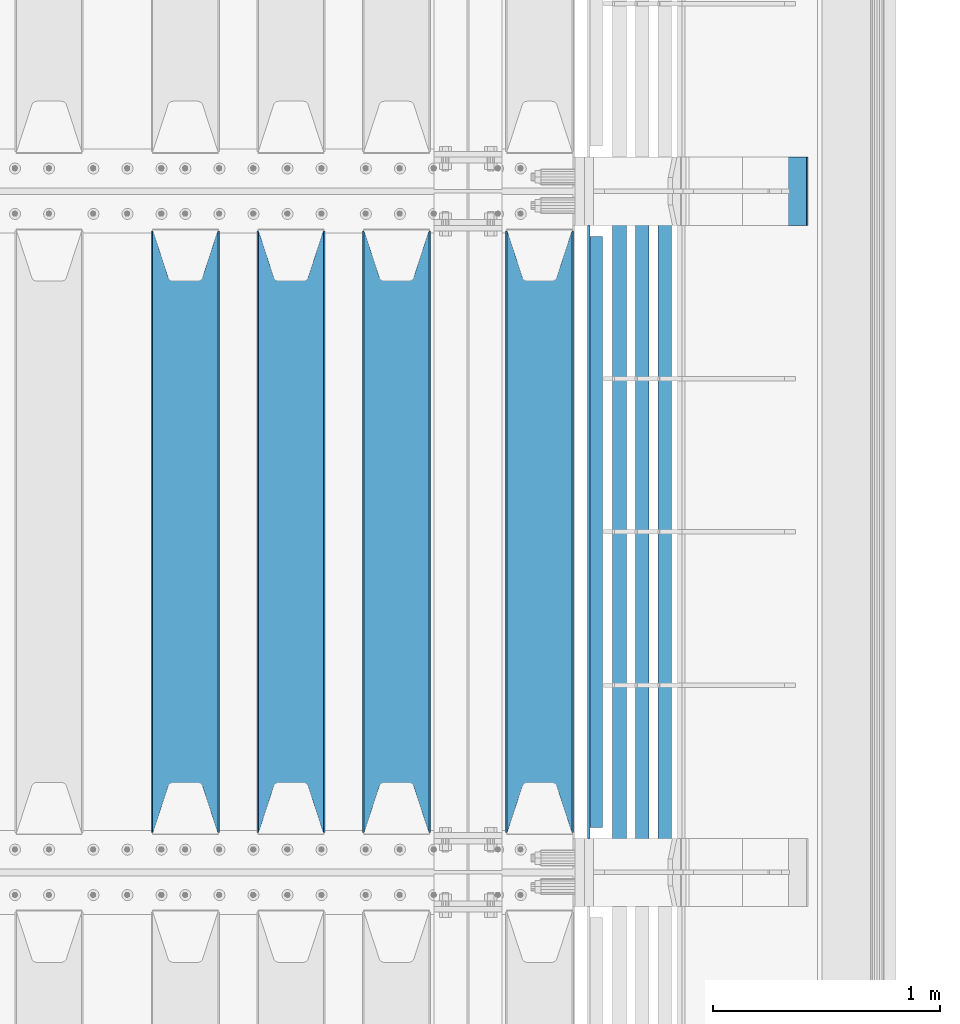
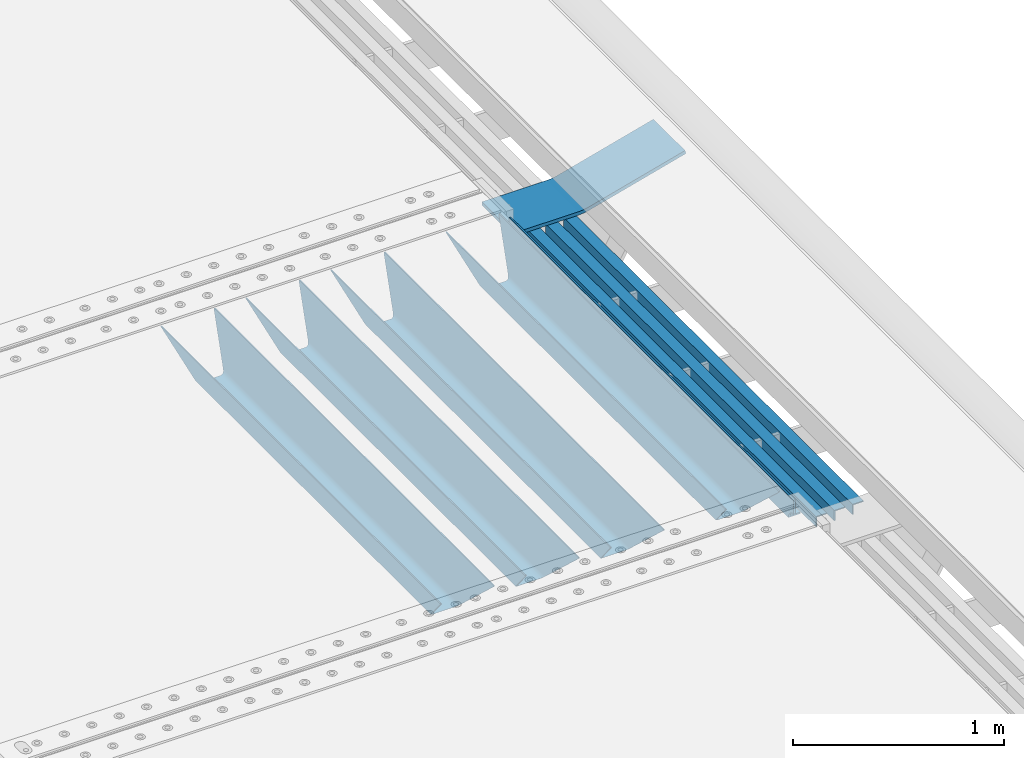
# One storey, part 131 of 257: 9 beams.
"""IFC2X3 building model written with IfcOpenShell, lengths in millimetres."""

from ifc_helpers import new_model, si_unit, frame, origin_with_axes, place, context, subcontext, project, spatial, faceted_brep, material, type_object, element, save


model = new_model("IFC2X3")

# Units and contexts
model_context = context("Model", 3, precision=1e-05, world=origin_with_axes())
body_context = subcontext(model_context, "Body", "Model", "MODEL_VIEW")
ifc_project = project(units=[si_unit("LENGTHUNIT", "METRE", prefix="MILLI"), si_unit("AREAUNIT", "SQUARE_METRE"), si_unit("VOLUMEUNIT", "CUBIC_METRE"), si_unit("MASSUNIT", "GRAM", prefix="KILO"), si_unit("TIMEUNIT", "SECOND"), si_unit("PLANEANGLEUNIT", "RADIAN"), si_unit("SOLIDANGLEUNIT", "STERADIAN"), si_unit("THERMODYNAMICTEMPERATUREUNIT", "DEGREE_CELSIUS"), si_unit("LUMINOUSINTENSITYUNIT", "LUMEN")], contexts=[model_context])

# Site, building, storey
site_placement = place(None, origin_with_axes())
site = spatial("IfcSite", under=ifc_project, at=site_placement, CompositionType="ELEMENT")
building_placement = place(site_placement, origin_with_axes())
building = spatial("IfcBuilding", under=site, at=building_placement, Name="Standard", CompositionType="ELEMENT")
storey_placement = place(building_placement, origin_with_axes())
storey = spatial("IfcBuildingStorey", under=building, at=storey_placement, Name="Undefined", CompositionType="ELEMENT", Elevation=0.0)

# Beams
ifc_material_1 = material(Name="STEEL/S355N")
beam_type_1 = type_object("IfcBeamType", PredefinedType="NOTDEFINED")
beam_1_placement = place(storey_placement, frame((59110.0, 3175.0, -115.0), z_axis=(0.0, 0.0, 1.0), x_axis=(0.0, 1.0, 0.0)))
element("IfcBeam", 1, at=beam_1_placement, inside=storey, type_object=beam_type_1, material=ifc_material_1, context=body_context, shape_type="Brep", body=[
    faceted_brep([(0.0, 150.0, 115.0), (0.0, 143.690000000002, 115.0), (2650.00000000297, 143.690000000002, 115.0), (2650.00000000297, 150.0, 115.0), (2650.00000000297, 142.059565218406, 110.0000000031), (2650.00000000297, 148.369565218403, 110.0000000031), (2441.90079219208, -80.1103600731149, -98.0992078077845), (2437.7588105432, -77.5672621345584, -102.241189456673), (2434.06523489746, -74.4080125315522, -105.934765102404), (2430.91086095089, -70.7102721255724, -109.089139048974), (2428.37322971128, -66.5649389910031, -111.626770288588), (2426.51472138055, -62.0739139532889, -113.485278619323), (2425.38102192091, -57.3475956567636, -114.618978078955), (2424.99999999987, -52.5021667386536, -115.0), (2424.99999999987, 52.5021667386536, -115.0), (2425.38102192091, 57.3475956567636, -114.618978078955), (2426.51472138055, 62.0739139532889, -113.485278619323), (2428.37322971128, 66.5649389910031, -111.626770288588), (2430.91086095089, 70.7102721255724, -109.089139048974), (2434.06523489746, 74.4080125315522, -105.934765102404), (2437.7588105432, 77.5672621345584, -102.241189456673), (2441.90079219208, 80.1103600731149, -98.0992078077846), (2446.38936140511, 81.9747917625791, -93.6106385947584), (2448.24948500409, 76.2713538057287, -91.7505149957729), (2444.62967112262, 74.76777986261, -95.3703288772456), (2441.28936334126, 72.7168944282894, -98.710636658607), (2438.31067330438, 70.1691124903809, -101.689326695487), (2435.76682334747, 67.1870637758839, -104.233176652398), (2433.72034654133, 63.8440531834931, -106.279653458539), (2432.22154950041, 60.2222587982324, -107.778450499454), (2431.30727574265, 56.4107117849126, -108.692724257221), (2430.99999999987, 52.5031078186876, -109.0), (2430.99999999987, -52.5031078186876, -109.0), (2431.30727574265, -56.4107117849126, -108.692724257221), (2432.22154950041, -60.2222587982324, -107.778450499454), (2433.72034654133, -63.8440531834931, -106.279653458539), (2435.76682334747, -67.1870637758839, -104.233176652398), (2438.31067330438, -70.1691124903809, -101.689326695487), (2441.28936334126, -72.7168944282894, -98.7106366586071), (2444.62967112262, -74.76777986261, -95.3703288772457), (2448.24948500409, -76.2713538057287, -91.7505149957729), (2650.00000000297, -142.059565218406, 110.0000000031), (2650.00000000297, -148.369565218403, 110.0000000031), (2446.38936140511, -81.9747917625791, -93.6106385947584), (2650.00000000297, -143.690000000002, 115.0), (2650.00000000297, -150.0, 115.0), (0.0, -143.690000000002, 115.0), (0.0, -150.0, 115.0), (0.0, -148.369565218258, 110.000000002662), (203.61063859742, -81.9747917625791, -93.6106385947584), (208.099207810447, -80.1103600731149, -98.0992078077845), (212.241189459335, -77.5672621345584, -102.241189456673), (215.934765105066, -74.4080125315522, -105.934765102404), (219.089139051636, -70.7102721255724, -109.089139048974), (221.626770291251, -66.5649389910031, -111.626770288588), (223.485278621985, -62.0739139532889, -113.485278619323), (224.618978081617, -57.3475956567636, -114.618978078955), (225.000000002662, -52.5021667386536, -115.0), (225.000000002662, 52.5021667386536, -115.0), (224.618978081617, 57.3475956567636, -114.618978078955), (223.485278621985, 62.0739139532889, -113.485278619323), (221.626770291251, 66.5649389910031, -111.626770288588), (219.089139051636, 70.7102721255724, -109.089139048974), (215.934765105066, 74.4080125315522, -105.934765102404), (212.241189459335, 77.5672621345584, -102.241189456673), (208.099207810447, 80.1103600731149, -98.0992078077846), (203.61063859742, 81.9747917625791, -93.6106385947584), (0.0, 148.369565218258, 110.000000002662), (0.0, 142.05956521826, 110.000000002662), (201.750514998435, 76.2713538057287, -91.7505149957729), (205.370328879908, 74.76777986261, -95.3703288772456), (208.710636661269, 72.7168944282894, -98.710636658607), (211.689326698149, 70.1691124903809, -101.689326695487), (214.233176655061, 67.1870637758839, -104.233176652398), (216.279653461201, 63.8440531834931, -106.279653458539), (217.778450502116, 60.2222587982324, -107.778450499454), (218.692724259884, 56.4107117849126, -108.692724257221), (219.000000002662, 52.5031078186876, -109.0), (219.000000002662, -52.5031078186876, -109.0), (218.692724259884, -56.4107117849126, -108.692724257221), (217.778450502116, -60.2222587982324, -107.778450499454), (216.279653461201, -63.8440531834931, -106.279653458539), (214.233176655061, -67.1870637758839, -104.233176652398), (211.689326698149, -70.1691124903809, -101.689326695487), (208.710636661269, -72.7168944282894, -98.7106366586071), (205.370328879908, -74.76777986261, -95.3703288772457), (201.750514998435, -76.2713538057287, -91.7505149957729), (0.0, -142.05956521826, 110.000000002662)], [[[0, 1, 2, 3]], [[3, 2, 4, 5]], [[6, 7, 8, 9, 10, 11, 12, 13, 14, 15, 16, 17, 18, 19, 20, 21, 22, 5, 4, 23, 24, 25, 26, 27, 28, 29, 30, 31, 32, 33, 34, 35, 36, 37, 38, 39, 40, 41, 42, 43]], [[44, 45, 42, 41]], [[46, 47, 45, 44]], [[43, 42, 45, 47, 48, 49]], [[6, 43, 49, 50]], [[7, 6, 50, 51]], [[8, 7, 51, 52]], [[9, 8, 52, 53]], [[10, 9, 53, 54]], [[11, 10, 54, 55]], [[12, 11, 55, 56]], [[13, 12, 56, 57]], [[14, 13, 57, 58]], [[15, 14, 58, 59]], [[16, 15, 59, 60]], [[17, 16, 60, 61]], [[18, 17, 61, 62]], [[19, 18, 62, 63]], [[20, 19, 63, 64]], [[21, 20, 64, 65]], [[22, 21, 65, 66]], [[0, 3, 5, 22, 66, 67]], [[1, 0, 67, 68]], [[23, 4, 2, 1, 68, 69]], [[24, 23, 69, 70]], [[25, 24, 70, 71]], [[26, 25, 71, 72]], [[27, 26, 72, 73]], [[28, 27, 73, 74]], [[29, 28, 74, 75]], [[30, 29, 75, 76]], [[31, 30, 76, 77]], [[32, 31, 77, 78]], [[33, 32, 78, 79]], [[34, 33, 79, 80]], [[35, 34, 80, 81]], [[36, 35, 81, 82]], [[37, 36, 82, 83]], [[38, 37, 83, 84]], [[39, 38, 84, 85]], [[40, 39, 85, 86]], [[46, 44, 41, 40, 86, 87]], [[47, 46, 87, 48]], [[86, 85, 84, 83, 82, 81, 80, 79, 78, 77, 76, 75, 74, 73, 72, 71, 70, 69, 68, 67, 66, 65, 64, 63, 62, 61, 60, 59, 58, 57, 56, 55, 54, 53, 52, 51, 50, 49, 48, 87]]]),
])
beam_2_placement = place(storey_placement, frame((58480.0, 3175.0, -115.0), z_axis=(0.0, 0.0, 1.0), x_axis=(0.0, 1.0, 0.0)))
element("IfcBeam", 2, at=beam_2_placement, inside=storey, type_object=beam_type_1, material=ifc_material_1, context=body_context, shape_type="Brep", body=[
    faceted_brep([(0.0, 150.0, 115.0), (0.0, 143.690000000002, 115.0), (2650.00000000297, 143.690000000002, 115.0), (2650.00000000297, 150.0, 115.0), (2650.00000000297, 142.059565218406, 110.0000000031), (2650.00000000297, 148.369565218403, 110.0000000031), (2441.90079219208, -80.1103600731149, -98.0992078077845), (2437.7588105432, -77.5672621345584, -102.241189456673), (2434.06523489746, -74.4080125315522, -105.934765102404), (2430.91086095089, -70.7102721255724, -109.089139048974), (2428.37322971128, -66.5649389910031, -111.626770288588), (2426.51472138055, -62.0739139532889, -113.485278619323), (2425.38102192091, -57.3475956567636, -114.618978078955), (2424.99999999987, -52.5021667386536, -115.0), (2424.99999999987, 52.5021667386536, -115.0), (2425.38102192091, 57.3475956567636, -114.618978078955), (2426.51472138055, 62.0739139532889, -113.485278619323), (2428.37322971128, 66.5649389910031, -111.626770288588), (2430.91086095089, 70.7102721255724, -109.089139048974), (2434.06523489746, 74.4080125315522, -105.934765102404), (2437.7588105432, 77.5672621345584, -102.241189456673), (2441.90079219208, 80.1103600731149, -98.0992078077846), (2446.38936140511, 81.9747917625791, -93.6106385947584), (2448.24948500409, 76.2713538057287, -91.7505149957729), (2444.62967112262, 74.76777986261, -95.3703288772456), (2441.28936334126, 72.7168944282894, -98.710636658607), (2438.31067330438, 70.1691124903809, -101.689326695487), (2435.76682334747, 67.1870637758839, -104.233176652398), (2433.72034654133, 63.8440531834931, -106.279653458539), (2432.22154950041, 60.2222587982324, -107.778450499454), (2431.30727574265, 56.4107117849126, -108.692724257221), (2430.99999999987, 52.5031078186876, -109.0), (2430.99999999987, -52.5031078186876, -109.0), (2431.30727574265, -56.4107117849126, -108.692724257221), (2432.22154950041, -60.2222587982324, -107.778450499454), (2433.72034654133, -63.8440531834931, -106.279653458539), (2435.76682334747, -67.1870637758839, -104.233176652398), (2438.31067330438, -70.1691124903809, -101.689326695487), (2441.28936334126, -72.7168944282894, -98.7106366586071), (2444.62967112262, -74.76777986261, -95.3703288772457), (2448.24948500409, -76.2713538057287, -91.7505149957729), (2650.00000000297, -142.059565218406, 110.0000000031), (2650.00000000297, -148.369565218403, 110.0000000031), (2446.38936140511, -81.9747917625791, -93.6106385947584), (2650.00000000297, -143.690000000002, 115.0), (2650.00000000297, -150.0, 115.0), (0.0, -143.690000000002, 115.0), (0.0, -150.0, 115.0), (0.0, -148.369565218258, 110.000000002662), (203.61063859742, -81.9747917625791, -93.6106385947584), (208.099207810447, -80.1103600731149, -98.0992078077845), (212.241189459335, -77.5672621345584, -102.241189456673), (215.934765105066, -74.4080125315522, -105.934765102404), (219.089139051636, -70.7102721255724, -109.089139048974), (221.626770291251, -66.5649389910031, -111.626770288588), (223.485278621985, -62.0739139532889, -113.485278619323), (224.618978081617, -57.3475956567636, -114.618978078955), (225.000000002662, -52.5021667386536, -115.0), (225.000000002662, 52.5021667386536, -115.0), (224.618978081617, 57.3475956567636, -114.618978078955), (223.485278621985, 62.0739139532889, -113.485278619323), (221.626770291251, 66.5649389910031, -111.626770288588), (219.089139051636, 70.7102721255724, -109.089139048974), (215.934765105066, 74.4080125315522, -105.934765102404), (212.241189459335, 77.5672621345584, -102.241189456673), (208.099207810447, 80.1103600731149, -98.0992078077846), (203.61063859742, 81.9747917625791, -93.6106385947584), (0.0, 148.369565218258, 110.000000002662), (0.0, 142.05956521826, 110.000000002662), (201.750514998435, 76.2713538057287, -91.7505149957729), (205.370328879908, 74.76777986261, -95.3703288772456), (208.710636661269, 72.7168944282894, -98.710636658607), (211.689326698149, 70.1691124903809, -101.689326695487), (214.233176655061, 67.1870637758839, -104.233176652398), (216.279653461201, 63.8440531834931, -106.279653458539), (217.778450502116, 60.2222587982324, -107.778450499454), (218.692724259884, 56.4107117849126, -108.692724257221), (219.000000002662, 52.5031078186876, -109.0), (219.000000002662, -52.5031078186876, -109.0), (218.692724259884, -56.4107117849126, -108.692724257221), (217.778450502116, -60.2222587982324, -107.778450499454), (216.279653461201, -63.8440531834931, -106.279653458539), (214.233176655061, -67.1870637758839, -104.233176652398), (211.689326698149, -70.1691124903809, -101.689326695487), (208.710636661269, -72.7168944282894, -98.7106366586071), (205.370328879908, -74.76777986261, -95.3703288772457), (201.750514998435, -76.2713538057287, -91.7505149957729), (0.0, -142.05956521826, 110.000000002662)], [[[0, 1, 2, 3]], [[3, 2, 4, 5]], [[6, 7, 8, 9, 10, 11, 12, 13, 14, 15, 16, 17, 18, 19, 20, 21, 22, 5, 4, 23, 24, 25, 26, 27, 28, 29, 30, 31, 32, 33, 34, 35, 36, 37, 38, 39, 40, 41, 42, 43]], [[44, 45, 42, 41]], [[46, 47, 45, 44]], [[43, 42, 45, 47, 48, 49]], [[6, 43, 49, 50]], [[7, 6, 50, 51]], [[8, 7, 51, 52]], [[9, 8, 52, 53]], [[10, 9, 53, 54]], [[11, 10, 54, 55]], [[12, 11, 55, 56]], [[13, 12, 56, 57]], [[14, 13, 57, 58]], [[15, 14, 58, 59]], [[16, 15, 59, 60]], [[17, 16, 60, 61]], [[18, 17, 61, 62]], [[19, 18, 62, 63]], [[20, 19, 63, 64]], [[21, 20, 64, 65]], [[22, 21, 65, 66]], [[0, 3, 5, 22, 66, 67]], [[1, 0, 67, 68]], [[23, 4, 2, 1, 68, 69]], [[24, 23, 69, 70]], [[25, 24, 70, 71]], [[26, 25, 71, 72]], [[27, 26, 72, 73]], [[28, 27, 73, 74]], [[29, 28, 74, 75]], [[30, 29, 75, 76]], [[31, 30, 76, 77]], [[32, 31, 77, 78]], [[33, 32, 78, 79]], [[34, 33, 79, 80]], [[35, 34, 80, 81]], [[36, 35, 81, 82]], [[37, 36, 82, 83]], [[38, 37, 83, 84]], [[39, 38, 84, 85]], [[40, 39, 85, 86]], [[46, 44, 41, 40, 86, 87]], [[47, 46, 87, 48]], [[86, 85, 84, 83, 82, 81, 80, 79, 78, 77, 76, 75, 74, 73, 72, 71, 70, 69, 68, 67, 66, 65, 64, 63, 62, 61, 60, 59, 58, 57, 56, 55, 54, 53, 52, 51, 50, 49, 48, 87]]]),
])
beam_3_placement = place(storey_placement, frame((58015.0, 3175.0, -115.0), z_axis=(0.0, 0.0, 1.0), x_axis=(0.0, 1.0, 0.0)))
element("IfcBeam", 3, at=beam_3_placement, inside=storey, type_object=beam_type_1, material=ifc_material_1, context=body_context, shape_type="Brep", body=[
    faceted_brep([(0.0, 150.0, 115.0), (0.0, 143.690000000002, 115.0), (2650.00000000297, 143.690000000002, 115.0), (2650.00000000297, 150.0, 115.0), (2650.00000000297, 142.059565218406, 110.0000000031), (2650.00000000297, 148.369565218403, 110.0000000031), (2441.90079219208, -80.1103600731149, -98.0992078077845), (2437.7588105432, -77.5672621345584, -102.241189456673), (2434.06523489746, -74.4080125315522, -105.934765102404), (2430.91086095089, -70.7102721255724, -109.089139048974), (2428.37322971128, -66.5649389910031, -111.626770288588), (2426.51472138055, -62.0739139532889, -113.485278619323), (2425.38102192091, -57.3475956567636, -114.618978078955), (2424.99999999987, -52.5021667386536, -115.0), (2424.99999999987, 52.5021667386536, -115.0), (2425.38102192091, 57.3475956567636, -114.618978078955), (2426.51472138055, 62.0739139532889, -113.485278619323), (2428.37322971128, 66.5649389910031, -111.626770288588), (2430.91086095089, 70.7102721255724, -109.089139048974), (2434.06523489746, 74.4080125315522, -105.934765102404), (2437.7588105432, 77.5672621345584, -102.241189456673), (2441.90079219208, 80.1103600731149, -98.0992078077846), (2446.38936140511, 81.9747917625791, -93.6106385947584), (2448.24948500409, 76.2713538057287, -91.7505149957729), (2444.62967112262, 74.76777986261, -95.3703288772456), (2441.28936334126, 72.7168944282894, -98.710636658607), (2438.31067330438, 70.1691124903809, -101.689326695487), (2435.76682334747, 67.1870637758839, -104.233176652398), (2433.72034654133, 63.8440531834931, -106.279653458539), (2432.22154950041, 60.2222587982324, -107.778450499454), (2431.30727574265, 56.4107117849126, -108.692724257221), (2430.99999999987, 52.5031078186876, -109.0), (2430.99999999987, -52.5031078186876, -109.0), (2431.30727574265, -56.4107117849126, -108.692724257221), (2432.22154950041, -60.2222587982324, -107.778450499454), (2433.72034654133, -63.8440531834931, -106.279653458539), (2435.76682334747, -67.1870637758839, -104.233176652398), (2438.31067330438, -70.1691124903809, -101.689326695487), (2441.28936334126, -72.7168944282894, -98.7106366586071), (2444.62967112262, -74.76777986261, -95.3703288772457), (2448.24948500409, -76.2713538057287, -91.7505149957729), (2650.00000000297, -142.059565218406, 110.0000000031), (2650.00000000297, -148.369565218403, 110.0000000031), (2446.38936140511, -81.9747917625791, -93.6106385947584), (2650.00000000297, -143.690000000002, 115.0), (2650.00000000297, -150.0, 115.0), (0.0, -143.690000000002, 115.0), (0.0, -150.0, 115.0), (0.0, -148.369565218258, 110.000000002662), (203.61063859742, -81.9747917625791, -93.6106385947584), (208.099207810447, -80.1103600731149, -98.0992078077845), (212.241189459335, -77.5672621345584, -102.241189456673), (215.934765105066, -74.4080125315522, -105.934765102404), (219.089139051636, -70.7102721255724, -109.089139048974), (221.626770291251, -66.5649389910031, -111.626770288588), (223.485278621985, -62.0739139532889, -113.485278619323), (224.618978081617, -57.3475956567636, -114.618978078955), (225.000000002662, -52.5021667386536, -115.0), (225.000000002662, 52.5021667386536, -115.0), (224.618978081617, 57.3475956567636, -114.618978078955), (223.485278621985, 62.0739139532889, -113.485278619323), (221.626770291251, 66.5649389910031, -111.626770288588), (219.089139051636, 70.7102721255724, -109.089139048974), (215.934765105066, 74.4080125315522, -105.934765102404), (212.241189459335, 77.5672621345584, -102.241189456673), (208.099207810447, 80.1103600731149, -98.0992078077846), (203.61063859742, 81.9747917625791, -93.6106385947584), (0.0, 148.369565218258, 110.000000002662), (0.0, 142.05956521826, 110.000000002662), (201.750514998435, 76.2713538057287, -91.7505149957729), (205.370328879908, 74.76777986261, -95.3703288772456), (208.710636661269, 72.7168944282894, -98.710636658607), (211.689326698149, 70.1691124903809, -101.689326695487), (214.233176655061, 67.1870637758839, -104.233176652398), (216.279653461201, 63.8440531834931, -106.279653458539), (217.778450502116, 60.2222587982324, -107.778450499454), (218.692724259884, 56.4107117849126, -108.692724257221), (219.000000002662, 52.5031078186876, -109.0), (219.000000002662, -52.5031078186876, -109.0), (218.692724259884, -56.4107117849126, -108.692724257221), (217.778450502116, -60.2222587982324, -107.778450499454), (216.279653461201, -63.8440531834931, -106.279653458539), (214.233176655061, -67.1870637758839, -104.233176652398), (211.689326698149, -70.1691124903809, -101.689326695487), (208.710636661269, -72.7168944282894, -98.7106366586071), (205.370328879908, -74.76777986261, -95.3703288772457), (201.750514998435, -76.2713538057287, -91.7505149957729), (0.0, -142.05956521826, 110.000000002662)], [[[0, 1, 2, 3]], [[3, 2, 4, 5]], [[6, 7, 8, 9, 10, 11, 12, 13, 14, 15, 16, 17, 18, 19, 20, 21, 22, 5, 4, 23, 24, 25, 26, 27, 28, 29, 30, 31, 32, 33, 34, 35, 36, 37, 38, 39, 40, 41, 42, 43]], [[44, 45, 42, 41]], [[46, 47, 45, 44]], [[43, 42, 45, 47, 48, 49]], [[6, 43, 49, 50]], [[7, 6, 50, 51]], [[8, 7, 51, 52]], [[9, 8, 52, 53]], [[10, 9, 53, 54]], [[11, 10, 54, 55]], [[12, 11, 55, 56]], [[13, 12, 56, 57]], [[14, 13, 57, 58]], [[15, 14, 58, 59]], [[16, 15, 59, 60]], [[17, 16, 60, 61]], [[18, 17, 61, 62]], [[19, 18, 62, 63]], [[20, 19, 63, 64]], [[21, 20, 64, 65]], [[22, 21, 65, 66]], [[0, 3, 5, 22, 66, 67]], [[1, 0, 67, 68]], [[23, 4, 2, 1, 68, 69]], [[24, 23, 69, 70]], [[25, 24, 70, 71]], [[26, 25, 71, 72]], [[27, 26, 72, 73]], [[28, 27, 73, 74]], [[29, 28, 74, 75]], [[30, 29, 75, 76]], [[31, 30, 76, 77]], [[32, 31, 77, 78]], [[33, 32, 78, 79]], [[34, 33, 79, 80]], [[35, 34, 80, 81]], [[36, 35, 81, 82]], [[37, 36, 82, 83]], [[38, 37, 83, 84]], [[39, 38, 84, 85]], [[40, 39, 85, 86]], [[46, 44, 41, 40, 86, 87]], [[47, 46, 87, 48]], [[86, 85, 84, 83, 82, 81, 80, 79, 78, 77, 76, 75, 74, 73, 72, 71, 70, 69, 68, 67, 66, 65, 64, 63, 62, 61, 60, 59, 58, 57, 56, 55, 54, 53, 52, 51, 50, 49, 48, 87]]]),
])
beam_4_placement = place(storey_placement, frame((57550.0, 3175.0, -115.0), z_axis=(0.0, 0.0, 1.0), x_axis=(0.0, 1.0, 0.0)))
element("IfcBeam", 4, at=beam_4_placement, inside=storey, type_object=beam_type_1, material=ifc_material_1, context=body_context, shape_type="Brep", body=[
    faceted_brep([(0.0, 150.0, 115.0), (0.0, 143.690000000002, 115.0), (2650.00000000297, 143.690000000002, 115.0), (2650.00000000297, 150.0, 115.0), (2650.00000000297, 142.059565218406, 110.0000000031), (2650.00000000297, 148.369565218403, 110.0000000031), (2441.90079219208, -80.1103600731149, -98.0992078077845), (2437.7588105432, -77.5672621345584, -102.241189456673), (2434.06523489746, -74.4080125315522, -105.934765102404), (2430.91086095089, -70.7102721255724, -109.089139048974), (2428.37322971128, -66.5649389910031, -111.626770288588), (2426.51472138055, -62.0739139532889, -113.485278619323), (2425.38102192091, -57.3475956567636, -114.618978078955), (2424.99999999987, -52.5021667386536, -115.0), (2424.99999999987, 52.5021667386536, -115.0), (2425.38102192091, 57.3475956567636, -114.618978078955), (2426.51472138055, 62.0739139532889, -113.485278619323), (2428.37322971128, 66.5649389910031, -111.626770288588), (2430.91086095089, 70.7102721255724, -109.089139048974), (2434.06523489746, 74.4080125315522, -105.934765102404), (2437.7588105432, 77.5672621345584, -102.241189456673), (2441.90079219208, 80.1103600731149, -98.0992078077846), (2446.38936140511, 81.9747917625791, -93.6106385947584), (2448.24948500409, 76.2713538057287, -91.7505149957729), (2444.62967112262, 74.76777986261, -95.3703288772456), (2441.28936334126, 72.7168944282894, -98.710636658607), (2438.31067330438, 70.1691124903809, -101.689326695487), (2435.76682334747, 67.1870637758839, -104.233176652398), (2433.72034654133, 63.8440531834931, -106.279653458539), (2432.22154950041, 60.2222587982324, -107.778450499454), (2431.30727574265, 56.4107117849126, -108.692724257221), (2430.99999999987, 52.5031078186876, -109.0), (2430.99999999987, -52.5031078186876, -109.0), (2431.30727574265, -56.4107117849126, -108.692724257221), (2432.22154950041, -60.2222587982324, -107.778450499454), (2433.72034654133, -63.8440531834931, -106.279653458539), (2435.76682334747, -67.1870637758839, -104.233176652398), (2438.31067330438, -70.1691124903809, -101.689326695487), (2441.28936334126, -72.7168944282894, -98.7106366586071), (2444.62967112262, -74.76777986261, -95.3703288772457), (2448.24948500409, -76.2713538057287, -91.7505149957729), (2650.00000000297, -142.059565218406, 110.0000000031), (2650.00000000297, -148.369565218403, 110.0000000031), (2446.38936140511, -81.9747917625791, -93.6106385947584), (2650.00000000297, -143.690000000002, 115.0), (2650.00000000297, -150.0, 115.0), (0.0, -143.690000000002, 115.0), (0.0, -150.0, 115.0), (0.0, -148.369565218258, 110.000000002662), (203.61063859742, -81.9747917625791, -93.6106385947584), (208.099207810447, -80.1103600731149, -98.0992078077845), (212.241189459335, -77.5672621345584, -102.241189456673), (215.934765105066, -74.4080125315522, -105.934765102404), (219.089139051636, -70.7102721255724, -109.089139048974), (221.626770291251, -66.5649389910031, -111.626770288588), (223.485278621985, -62.0739139532889, -113.485278619323), (224.618978081617, -57.3475956567636, -114.618978078955), (225.000000002662, -52.5021667386536, -115.0), (225.000000002662, 52.5021667386536, -115.0), (224.618978081617, 57.3475956567636, -114.618978078955), (223.485278621985, 62.0739139532889, -113.485278619323), (221.626770291251, 66.5649389910031, -111.626770288588), (219.089139051636, 70.7102721255724, -109.089139048974), (215.934765105066, 74.4080125315522, -105.934765102404), (212.241189459335, 77.5672621345584, -102.241189456673), (208.099207810447, 80.1103600731149, -98.0992078077846), (203.61063859742, 81.9747917625791, -93.6106385947584), (0.0, 148.369565218258, 110.000000002662), (0.0, 142.05956521826, 110.000000002662), (201.750514998435, 76.2713538057287, -91.7505149957729), (205.370328879908, 74.76777986261, -95.3703288772456), (208.710636661269, 72.7168944282894, -98.710636658607), (211.689326698149, 70.1691124903809, -101.689326695487), (214.233176655061, 67.1870637758839, -104.233176652398), (216.279653461201, 63.8440531834931, -106.279653458539), (217.778450502116, 60.2222587982324, -107.778450499454), (218.692724259884, 56.4107117849126, -108.692724257221), (219.000000002662, 52.5031078186876, -109.0), (219.000000002662, -52.5031078186876, -109.0), (218.692724259884, -56.4107117849126, -108.692724257221), (217.778450502116, -60.2222587982324, -107.778450499454), (216.279653461201, -63.8440531834931, -106.279653458539), (214.233176655061, -67.1870637758839, -104.233176652398), (211.689326698149, -70.1691124903809, -101.689326695487), (208.710636661269, -72.7168944282894, -98.7106366586071), (205.370328879908, -74.76777986261, -95.3703288772457), (201.750514998435, -76.2713538057287, -91.7505149957729), (0.0, -142.05956521826, 110.000000002662)], [[[0, 1, 2, 3]], [[3, 2, 4, 5]], [[6, 7, 8, 9, 10, 11, 12, 13, 14, 15, 16, 17, 18, 19, 20, 21, 22, 5, 4, 23, 24, 25, 26, 27, 28, 29, 30, 31, 32, 33, 34, 35, 36, 37, 38, 39, 40, 41, 42, 43]], [[44, 45, 42, 41]], [[46, 47, 45, 44]], [[43, 42, 45, 47, 48, 49]], [[6, 43, 49, 50]], [[7, 6, 50, 51]], [[8, 7, 51, 52]], [[9, 8, 52, 53]], [[10, 9, 53, 54]], [[11, 10, 54, 55]], [[12, 11, 55, 56]], [[13, 12, 56, 57]], [[14, 13, 57, 58]], [[15, 14, 58, 59]], [[16, 15, 59, 60]], [[17, 16, 60, 61]], [[18, 17, 61, 62]], [[19, 18, 62, 63]], [[20, 19, 63, 64]], [[21, 20, 64, 65]], [[22, 21, 65, 66]], [[0, 3, 5, 22, 66, 67]], [[1, 0, 67, 68]], [[23, 4, 2, 1, 68, 69]], [[24, 23, 69, 70]], [[25, 24, 70, 71]], [[26, 25, 71, 72]], [[27, 26, 72, 73]], [[28, 27, 73, 74]], [[29, 28, 74, 75]], [[30, 29, 75, 76]], [[31, 30, 76, 77]], [[32, 31, 77, 78]], [[33, 32, 78, 79]], [[34, 33, 79, 80]], [[35, 34, 80, 81]], [[36, 35, 81, 82]], [[37, 36, 82, 83]], [[38, 37, 83, 84]], [[39, 38, 84, 85]], [[40, 39, 85, 86]], [[46, 44, 41, 40, 86, 87]], [[47, 46, 87, 48]], [[86, 85, 84, 83, 82, 81, 80, 79, 78, 77, 76, 75, 74, 73, 72, 71, 70, 69, 68, 67, 66, 65, 64, 63, 62, 61, 60, 59, 58, 57, 56, 55, 54, 53, 52, 51, 50, 49, 48, 87]]]),
])
ifc_material_2 = material(Name="STEEL/S355J2")
beam_type_2 = type_object("IfcBeamType", PredefinedType="NOTDEFINED")
beam_5_placement = place(storey_placement, frame((59354.5025260065, 3150.0, -124.999999999977), z_axis=(0.0, 0.0, 1.0), x_axis=(0.0, 1.0, 0.0)))
element("IfcBeam", 5, at=beam_5_placement, inside=storey, type_object=beam_type_2, material=ifc_material_2, context=body_context, shape_type="Brep", body=[
    faceted_brep([(2700.0, 22.5, -15.0), (2684.54915028125, 22.5, -17.4471741852423), (2684.54915028125, 32.5, -17.4471741852423), (2700.0, 32.5, -15.0), (2670.61073738538, 22.5, -24.5491502812526), (2670.61073738538, 32.5, -24.5491502812526), (2659.54915028125, 22.5, -35.6107373853764), (2659.54915028125, 32.5, -35.6107373853764), (2652.44717418524, 22.5, -49.5491502812526), (2652.44717418524, 32.5, -49.5491502812526), (2651.58384440325, -32.5, -55.0), (2650.0, -32.5, -65.0), (2650.0, 32.5, -65.0), (2651.58384440325, 22.5, -55.0), (0.0, 32.5, 65.0), (0.0, 22.5, 65.0), (2700.0, 22.5, 65.0), (2700.0, 32.5, 65.0), (0.0, 32.5, -15.0), (0.0, 22.5, -15.0), (15.4508497187474, 32.5, -17.4471741852423), (15.4508497187474, 22.5, -17.4471741852423), (29.3892626146236, 32.5, -24.5491502812526), (29.3892626146236, 22.5, -24.5491502812526), (40.4508497187473, 32.5, -35.6107373853763), (40.4508497187473, 22.5, -35.6107373853763), (47.5528258147577, 32.5, -49.5491502812526), (47.5528258147577, 22.5, -49.5491502812526), (50.0, -32.5, -65.0), (48.4161555967548, -32.5, -55.0), (48.4161555967548, 22.5, -55.0), (50.0, 32.5, -65.0)], [[[0, 1, 2, 3]], [[4, 5, 2, 1]], [[6, 7, 5, 4]], [[8, 9, 7, 6]], [[10, 11, 12, 9, 8, 13]], [[14, 15, 16, 17]], [[15, 14, 18, 19]], [[19, 18, 20, 21]], [[21, 20, 22, 23]], [[23, 22, 24, 25]], [[25, 24, 26, 27]], [[28, 29, 30, 27, 26, 31]], [[30, 29, 10, 13]], [[16, 15, 19, 21, 23, 25, 27, 30, 13, 8, 6, 4, 1, 0]], [[17, 16, 0, 3]], [[5, 7, 9, 12, 31, 26, 24, 22, 20, 18, 14, 17, 3, 2]], [[28, 31, 12, 11]], [[29, 28, 11, 10]]]),
])
beam_type_3 = type_object("IfcBeamType", PredefinedType="NOTDEFINED")
beam_6_placement = place(storey_placement, frame((59346.9988298907, 6000.0, -169.999999999995), z_axis=(0.0, -1.0, 0.0), x_axis=(1.0, 0.0, 0.0)))
element("IfcBeam", 6, at=beam_6_placement, inside=storey, type_object=beam_type_3, material=ifc_material_1, context=body_context, shape_type="Brep", body=[
    faceted_brep([(0.0, 10.0, -150.0), (0.0, 10.0, 150.0), (356.495387467709, 10.0, 150.0), (356.495387467709, 10.0000000000045, -150.0), (0.0, -10.0, 150.0), (0.0, -10.0, -150.0), (356.495387467709, -10.0, -150.0), (356.495387467709, -10.0, 150.0), (382.770279632619, 11.7334369042663, 150.0), (382.770279632619, 11.7334369042663, -150.0), (385.397768849085, -8.09321940530714, -150.0), (385.397768849085, -8.09321940530714, 150.0), (413.799145685371, -2.4059304593832, -150.0), (413.799145685371, -2.4059304593832, 150.0), (408.589713120156, 16.9036995823731, 150.0), (408.589713119858, 16.9036995827009, -150.0), (938.999999999978, 160.0, 150.0), (938.999999999978, 160.0, -150.0), (944.209432565192, 140.69036995827, 150.0), (944.209432565192, 140.69036995827, -150.0)], [[[0, 1, 2, 3]], [[4, 5, 6, 7]], [[5, 4, 1, 0]], [[3, 2, 8, 9]], [[7, 6, 10, 11]], [[10, 12, 13, 11]], [[8, 14, 15, 9]], [[15, 14, 16, 17]], [[14, 8, 2, 1, 4, 7, 11, 13, 18, 16]], [[13, 12, 19, 18]], [[12, 10, 6, 5, 0, 3, 9, 15, 17, 19]], [[18, 19, 17, 16]]]),
])
beam_type_4 = type_object("IfcBeamType", PredefinedType="NOTDEFINED")
for number, where, z_axis, x_axis in (
    (7, (59662.0025260169, 5869.9999003886, -209.999999999563), (0.0, 0.0, -1.0), (0.0, -1.0, 0.0)),
    (8, (59562.0025260169, 5869.99990038863, -209.999999999563), (0.0, 0.0, -1.0), (0.0, -1.0, 0.0)),
    (9, (59462.0025260162, 5870.00000231317, -209.999999999622), (0.0, 0.0, -1.0), (0.0, -1.0, 0.0)),
):
    element("IfcBeam", number, at=place(storey_placement, frame(where, z_axis=z_axis, x_axis=x_axis)), inside=storey, type_object=beam_type_4, material=ifc_material_2, context=body_context, shape_type="Brep", body=[
        faceted_brep([(-9.09494701772928e-13, 29.9999999999854, -29.9999999999999), (-9.09494701772928e-13, 29.9999999999854, 30.0000000000001), (2740.00017042501, 29.9999999999854, 30.0000000000001), (2740.00017042501, 29.9999999999854, -29.9999999999999), (-9.09494701772928e-13, 23.9999999999854, 30.0), (2740.00017042501, 23.9999999999854, 30.0), (-1.81898940354586e-12, 23.9999999999854, -24.0), (2740.00017042501, 23.9999999999854, -24.0), (-1.81898940354586e-12, -30.0000000000146, -24.0), (2740.00017042501, -30.0000000000146, -24.0), (-1.81898940354586e-12, -30.0000000000146, -30.0), (2740.00017042501, -30.0000000000146, -30.0)], [[[0, 1, 2, 3]], [[1, 4, 5, 2]], [[4, 6, 7, 5]], [[6, 8, 9, 7]], [[8, 10, 11, 9]], [[10, 0, 3, 11]], [[5, 7, 9, 11, 3, 2]], [[10, 8, 6, 4, 1, 0]]]),
    ])

save(model, "model.ifc")
